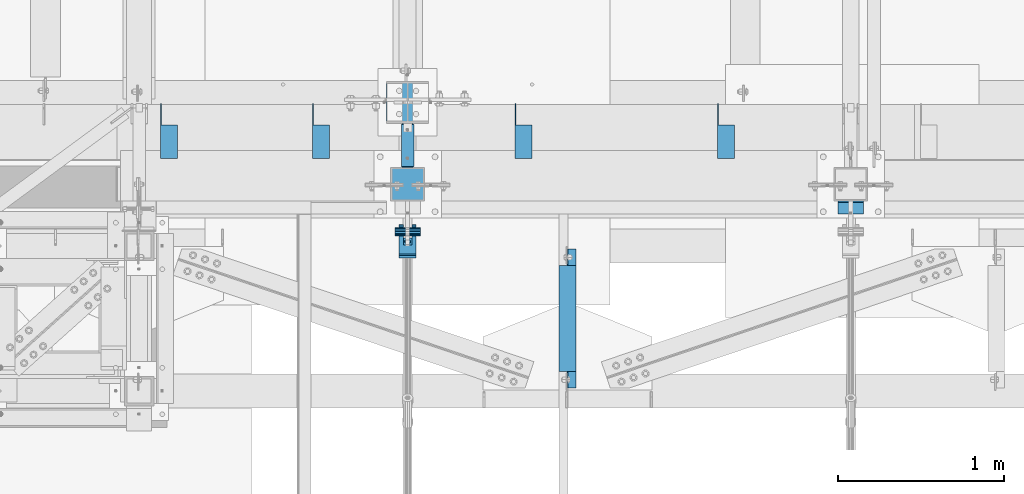
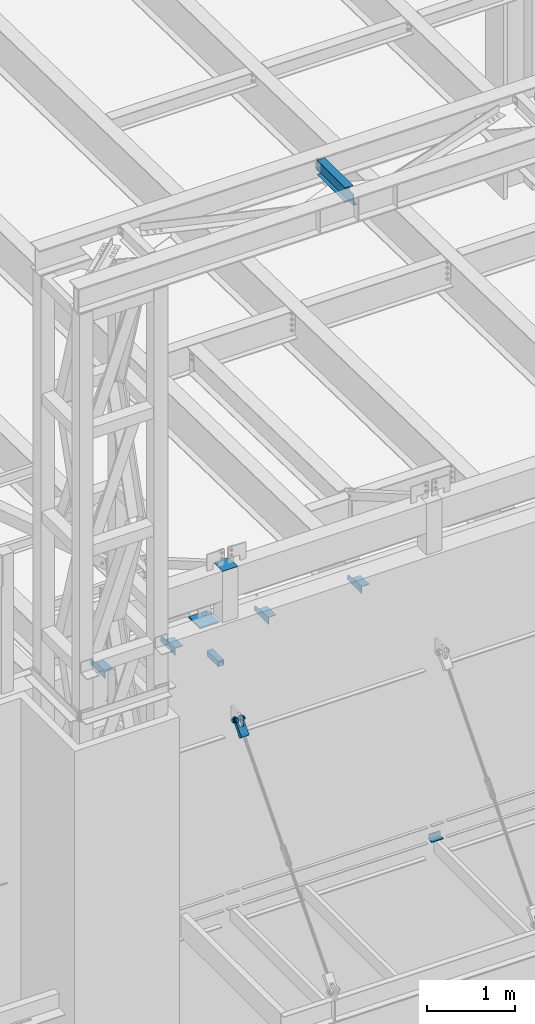
# One storey, part 1202 of 1763: 10 beams, 1 member, 8 elements without a shape of their own.
"""IFC2X3 building model written with IfcOpenShell, lengths in millimetres."""

from ifc_helpers import new_model, si_unit, frame, origin_with_axes, place, context, subcontext, project, spatial, faceted_brep, material, type_object, element, aggregate, save


model = new_model("IFC2X3")

# Units and contexts
model_context = context("Model", 3, precision=1e-05, world=origin_with_axes())
body_context = subcontext(model_context, "Body", "Model", "MODEL_VIEW")
ifc_project = project(units=[si_unit("LENGTHUNIT", "METRE", prefix="MILLI"), si_unit("AREAUNIT", "SQUARE_METRE"), si_unit("VOLUMEUNIT", "CUBIC_METRE"), si_unit("MASSUNIT", "GRAM", prefix="KILO"), si_unit("TIMEUNIT", "SECOND"), si_unit("PLANEANGLEUNIT", "RADIAN"), si_unit("SOLIDANGLEUNIT", "STERADIAN"), si_unit("THERMODYNAMICTEMPERATUREUNIT", "DEGREE_CELSIUS"), si_unit("LUMINOUSINTENSITYUNIT", "LUMEN")], contexts=[model_context])

# Site, building, storey
site_placement = place(None, origin_with_axes())
site = spatial("IfcSite", under=ifc_project, at=site_placement, CompositionType="ELEMENT")
building_placement = place(site_placement, origin_with_axes())
building = spatial("IfcBuilding", under=site, at=building_placement, Name="Undefined", CompositionType="ELEMENT")
storey_placement = place(building_placement, origin_with_axes())
storey = spatial("IfcBuildingStorey", under=building, at=storey_placement, Name="Undefined", CompositionType="ELEMENT", Elevation=0.0)

# Assembly, beams
assembly_1_placement = place(storey_placement, origin_with_axes())
assembly_1 = element("IfcElementAssembly", 1, at=assembly_1_placement, inside=storey, Name="BEAM", AssemblyPlace="NOTDEFINED", PredefinedType="RIGID_FRAME")
ifc_material_1 = material(Name="STEEL/A36")
beam_type_1 = type_object("IfcBeamType", Name="L4X4X1/4", PredefinedType="NOTDEFINED")
beam_1_placement = place(assembly_1_placement, frame((-59677.6055562795, -13723.1435701432, 12153.9), z_axis=(0.0, 0.0, -1.0), x_axis=(0.0, -1.0, 0.0)))
beam_1 = element("IfcBeam", 2, at=beam_1_placement, type_object=beam_type_1, material=ifc_material_1, Name="BRACE", ObjectType="L4X4X1/4", context=body_context, shape_type="Brep", body=[
    faceted_brep([(127.793748474227, 44.4499999999971, -31.7500007627295), (127.793748474227, 50.8000000000029, -31.7500007627295), (127.793748474225, 50.8000000000029, -50.7999999999993), (127.793748474225, -50.8000000000029, -50.7999999999993), (127.793748474225, -50.8000000000029, -44.4500000000007), (127.793748474225, 44.4499999999971, -44.4500000000007), (31.7499999999673, 44.4499999999971, -31.7500001906901), (31.7499999999673, 50.8000000000029, -31.7500007627295), (-1.81898940354586e-10, 44.4500000000371, 50.7999999999374), (-1.96450855582952e-10, 50.8000000000393, 50.7999999999374), (0.0, 50.8000000000029, -1.90690116141923e-07), (0.0, 44.4499999999971, -1.90690116141923e-07), (329.406260681253, 44.4499999999971, 50.7999999999993), (329.406260681253, 50.8000000000029, 50.7999999999993), (329.406260681253, 44.4499999999971, -44.4500000000007), (329.406260681253, -50.8000000000029, -44.4500000000007), (329.406260681253, -50.8000000000029, -50.7999999999993), (329.406260681253, 50.8000000000029, -50.7999999999993)], [[[0, 1, 2, 3, 4, 5]], [[1, 0, 6, 7]], [[8, 9, 10, 11]], [[9, 8, 12, 13]], [[12, 14, 15, 16, 17, 13]], [[15, 14, 5, 4]], [[16, 15, 4, 3]], [[17, 16, 3, 2]], [[9, 13, 17, 2, 1, 7, 10]], [[6, 11, 10, 7]], [[0, 5, 14, 12, 8, 11, 6]]]),
])
beam_2_placement = place(assembly_1_placement, frame((-60896.8055562795, -13723.1435701432, 12153.9), z_axis=(0.0, 0.0, -1.0), x_axis=(0.0, -1.0, 0.0)))
beam_2 = element("IfcBeam", 3, at=beam_2_placement, type_object=beam_type_1, material=ifc_material_1, Name="BRACE", ObjectType="L4X4X1/4", context=body_context, shape_type="Brep", body=[
    faceted_brep([(31.7499999999673, 44.4499999999971, -31.7500001906901), (0.0, 44.4499999999971, -1.90690116141923e-07), (0.0, 50.8000000000029, -1.90690116141923e-07), (31.7499999999673, 50.8000000000029, -31.7500007627295), (-1.96450855582952e-10, 50.8000000000393, 50.7999999999374), (-1.81898940354586e-10, 44.4500000000371, 50.7999999999374), (329.406260681253, 44.4499999999971, 50.7999999999993), (329.406260681253, 50.8000000000029, 50.7999999999993), (329.406260681253, -50.8000000000029, -50.7999999999993), (329.406260681253, -50.8000000000029, -44.4500000000007), (127.793748474225, -50.8000000000029, -44.4500000000007), (127.793748474225, -50.8000000000029, -50.7999999999993), (329.406260681253, 50.8000000000029, -50.7999999999993), (127.793748474225, 50.8000000000029, -50.7999999999993), (329.406260681253, 44.4499999999971, -44.4500000000007), (127.793748474225, 44.4499999999971, -44.4500000000007), (127.793748474227, 44.4499999999971, -31.7500007627295), (127.793748474227, 50.8000000000029, -31.7500007627295)], [[[0, 1, 2, 3]], [[4, 5, 6, 7]], [[8, 9, 10, 11]], [[12, 8, 11, 13]], [[6, 14, 9, 8, 12, 7]], [[9, 14, 15, 10]], [[16, 17, 13, 11, 10, 15]], [[17, 16, 0, 3]], [[4, 7, 12, 13, 17, 3, 2]], [[5, 4, 2, 1]], [[16, 15, 14, 6, 5, 1, 0]]]),
])
aggregate(assembly_1, [beam_1, beam_2])

assembly_2_placement = place(storey_placement, origin_with_axes())
assembly_2 = element("IfcElementAssembly", 4, at=assembly_2_placement, inside=storey, Name="BEAM", AssemblyPlace="NOTDEFINED", PredefinedType="RIGID_FRAME")
beam_3_placement = place(assembly_2_placement, frame((-62116.0055562795, -13723.1435701431, 12153.9), z_axis=(0.0, 0.0, -1.0), x_axis=(0.0, -1.0, 0.0)))
beam_3 = element("IfcBeam", 5, at=beam_3_placement, type_object=beam_type_1, material=ifc_material_1, Name="BRACE", ObjectType="L4X4X1/4", context=body_context, shape_type="Brep", body=[
    faceted_brep([(127.793748474227, 44.4499999999971, -31.7500007627295), (127.793748474227, 50.8000000000029, -31.7500007627295), (127.793748474225, 50.8000000000029, -50.7999999999993), (127.793748474225, -50.8000000000029, -50.7999999999993), (127.793748474225, -50.8000000000029, -44.4500000000007), (127.793748474225, 44.4499999999971, -44.4500000000007), (31.7499999999673, 44.4499999999971, -31.7500001906901), (31.7499999999673, 50.8000000000029, -31.7500007627295), (-1.81898940354586e-10, 44.4500000000371, 50.7999999999374), (-1.96450855582952e-10, 50.8000000000393, 50.7999999999374), (0.0, 50.8000000000029, -1.90690116141923e-07), (0.0, 44.4499999999971, -1.90690116141923e-07), (329.406260681253, 44.4499999999971, 50.7999999999993), (329.406260681253, 50.8000000000029, 50.7999999999993), (329.406260681253, 44.4499999999971, -44.4500000000007), (329.406260681253, -50.8000000000029, -44.4500000000007), (329.406260681253, -50.8000000000029, -50.7999999999993), (329.406260681253, 50.8000000000029, -50.7999999999993)], [[[0, 1, 2, 3, 4, 5]], [[1, 0, 6, 7]], [[8, 9, 10, 11]], [[9, 8, 12, 13]], [[12, 14, 15, 16, 17, 13]], [[15, 14, 5, 4]], [[16, 15, 4, 3]], [[17, 16, 3, 2]], [[9, 13, 17, 2, 1, 7, 10]], [[6, 11, 10, 7]], [[0, 5, 14, 12, 8, 11, 6]]]),
])
beam_4_placement = place(assembly_2_placement, frame((-63030.4055562795, -13723.1435701431, 12153.9), z_axis=(0.0, 0.0, -1.0), x_axis=(0.0, -1.0, 0.0)))
beam_4 = element("IfcBeam", 6, at=beam_4_placement, type_object=beam_type_1, material=ifc_material_1, Name="BRACE", ObjectType="L4X4X1/4", context=body_context, shape_type="Brep", body=[
    faceted_brep([(127.793748474227, 44.4499999999971, -31.7500007627295), (127.793748474227, 50.8000000000029, -31.7500007627295), (127.793748474225, 50.8000000000029, -50.7999999999993), (127.793748474225, -50.8000000000029, -50.7999999999993), (127.793748474225, -50.8000000000029, -44.4500000000007), (127.793748474225, 44.4499999999971, -44.4500000000007), (31.7499999999673, 44.4499999999971, -31.7500001906901), (31.7499999999673, 50.8000000000029, -31.7500007627295), (-1.81898940354586e-10, 44.4500000000371, 50.7999999999374), (-1.96450855582952e-10, 50.8000000000393, 50.7999999999374), (0.0, 50.8000000000029, -1.90690116141923e-07), (0.0, 44.4499999999971, -1.90690116141923e-07), (329.406260681253, 44.4499999999971, 50.7999999999993), (329.406260681253, 50.8000000000029, 50.7999999999993), (329.406260681253, 44.4499999999971, -44.4500000000007), (329.406260681253, -50.8000000000029, -44.4500000000007), (329.406260681253, -50.8000000000029, -50.7999999999993), (329.406260681253, 50.8000000000029, -50.7999999999993)], [[[0, 1, 2, 3, 4, 5]], [[1, 0, 6, 7]], [[8, 9, 10, 11]], [[9, 8, 12, 13]], [[12, 14, 15, 16, 17, 13]], [[15, 14, 5, 4]], [[16, 15, 4, 3]], [[17, 16, 3, 2]], [[9, 13, 17, 2, 1, 7, 10]], [[6, 11, 10, 7]], [[0, 5, 14, 12, 8, 11, 6]]]),
])
aggregate(assembly_2, [beam_3, beam_4])

# Assembly, beam
assembly_3_placement = place(storey_placement, origin_with_axes())
assembly_3 = element("IfcElementAssembly", 7, at=assembly_3_placement, inside=storey, Name="COLUMN", AssemblyPlace="NOTDEFINED", PredefinedType="RIGID_FRAME")
ifc_material_2 = material()
beam_type_2 = type_object("IfcBeamType", Name="HSS3X3X1/4", PredefinedType="NOTDEFINED")
beam_5_placement = place(assembly_3_placement, frame((-61594.4270098568, -14106.5276214906, 11825.2875), z_axis=(0.0, 0.0, 1.0), x_axis=(0.0, 1.0, 0.0)))
beam_5 = element("IfcBeam", 8, at=beam_5_placement, type_object=beam_type_2, material=ifc_material_2, Name="BEAM", ObjectType="HSS3X3X1/4", context=body_context, shape_type="Brep", body=[
    faceted_brep([(263.527621490564, 31.75, 31.75), (263.527621490564, 31.75, -31.75), (257.177621490564, 38.0999999999985, -38.1000000000004), (257.177621490564, 38.0999999999985, 38.1000000000004), (263.527621490564, -31.75, -31.75), (257.177621490564, -38.0999999999985, -38.1000000000004), (263.527621490564, -31.75, 31.75), (257.177621490564, -38.0999999999985, 38.1000000000004), (6.35000000000036, -38.0999999999985, -38.1000000000004), (0.0, -31.75, -31.75), (0.0, 31.75, -31.75), (6.35000000000036, 38.0999999999985, -38.1000000000004), (6.35000000000036, -38.0999999999985, 38.1000000000004), (0.0, -31.75, 31.75), (6.35000000000036, 38.0999999999985, 38.1000000000004), (0.0, 31.75, 31.75)], [[[0, 1, 2, 3]], [[4, 5, 2, 1]], [[6, 7, 5, 4]], [[8, 9, 10, 11]], [[12, 13, 9, 8]], [[14, 15, 13, 12]], [[13, 15, 0, 6]], [[9, 13, 6, 4]], [[10, 9, 4, 1]], [[15, 10, 1, 0]], [[14, 11, 10, 15]], [[11, 14, 3, 2]], [[8, 11, 2, 5]], [[12, 8, 5, 7]], [[14, 12, 7, 3]], [[0, 3, 7, 6]]]),
])

assembly_4_placement = place(storey_placement, origin_with_axes())
assembly_4 = element("IfcElementAssembly", 9, at=assembly_4_placement, inside=storey, Name="BEAM", AssemblyPlace="NOTDEFINED", PredefinedType="RIGID_FRAME")
ifc_material_3 = material(Name="STEEL/A992")
beam_type_3 = type_object("IfcBeamType", Name="W8X10", PredefinedType="NOTDEFINED")
beam_6_placement = place(assembly_4_placement, frame((-60631.3442297049, -15452.7273151462, 18721.3875), z_axis=(0.0, 0.0, 1.0), x_axis=(-6.21520000058808e-05, 0.999999998068564, 0.0)))
beam_6 = element("IfcBeam", 10, at=beam_6_placement, type_object=beam_type_3, material=ifc_material_3, Name="BEAM", ObjectType="W8X10", context=body_context, shape_type="Brep", body=[
    faceted_brep([(119.062681078214, 2.68119467444922, -95.25), (119.062681077521, 2.68146611312113, -100.012500000001), (17.4627485654109, 2.68120642377471, -100.012500000001), (17.4627485487254, 2.68093498508824, -95.25), (119.062558086149, 50.7999999995154, -95.25), (119.062558086149, 50.7999999995154, -100.012500000001), (119.062585395783, -2.38125000033324, 74.3525014877341), (119.062582114406, 2.38124999965657, 74.3525014877341), (118.095852191816, 2.38124999965657, 69.4924219696877), (118.095855473193, -2.38125000033324, 69.4924219696877), (115.342838291333, 2.38124999966385, 65.3722455015341), (115.342841572712, -2.38125000031869, 65.3722455015341), (111.222661823174, 2.38124999968568, 62.6192316010565), (111.222665104551, -2.38125000031141, 62.6192316010565), (106.362582305122, 2.38124999969295, 61.652501678469), (106.362585586499, -2.38125000029686, 61.652501678469), (17.4627301273904, 2.38124999994761, 61.652501678469), (17.4624373812949, -2.3812500000422, 61.652501678469), (17.4624373812949, -2.3812500000422, -95.25), (855.662438966074, -2.38125000246509, -95.25), (855.662438966074, -2.38125000246509, 61.652501678469), (766.762586825173, -2.38125000221044, 61.652501678469), (761.902507307121, -2.38125000219588, 62.6192316010565), (757.78233083896, -2.38125000218133, 65.3722455015341), (755.02931693848, -2.38125000217406, 69.4924219696877), (754.062587015891, -2.38125000216678, 74.3525014877341), (754.062587015991, -2.38125000216678, 95.25), (119.062585395672, -2.38125000033324, 95.25), (17.4594611293232, -50.7999999998938, -95.25), (855.6594627141, -50.8000000023239, -95.25), (17.4594611293232, -50.7999999998938, -100.012500000001), (855.6594627141, -50.8000000023239, -100.012500000001), (754.062536337649, 2.68190379224689, -95.25), (754.062536338066, 2.68163235356769, -100.012500000001), (754.062463102084, 50.7999999976746, -100.012500000001), (754.062463102084, 50.7999999976746, -95.25), (855.662750202562, 2.68205842697353, -95.25), (855.662750185877, 2.68178698828706, -100.012500000001), (855.662731712169, 2.38124999752472, -95.25), (855.662731712169, 2.38124999752472, 61.652501678469), (766.762583543798, 2.38124999777938, 61.652501678469), (761.902504025744, 2.38124999779393, 62.6192316010565), (757.782327557585, 2.38124999780848, 65.3722455015341), (755.029313657102, 2.38124999781576, 69.4924219696877), (754.062583734514, 2.38124999781576, 74.3525014877341), (754.062620376568, -50.8000000020329, 100.012500000001), (754.062620376568, -50.8000000020329, 95.25), (754.062583734623, 2.38124999781576, 95.25), (754.062550374047, 50.7999999976746, 95.25), (754.062550374047, 50.7999999976746, 100.012500000001), (119.062582114304, 2.38124999965657, 95.25), (119.062548753725, 50.7999999995227, 95.25), (119.062548753725, 50.7999999995227, 100.012500000001), (119.062618756248, -50.8000000001921, 100.012500000001), (119.062618756248, -50.8000000001921, 95.25), (17.4627301273904, 2.38124999994761, -95.25)], [[[0, 1, 2, 3]], [[4, 5, 1, 0]], [[6, 7, 8, 9]], [[9, 8, 10, 11]], [[11, 10, 12, 13]], [[13, 12, 14, 15]], [[15, 14, 16, 17]], [[9, 11, 13, 15, 17, 18, 19, 20, 21, 22, 23, 24, 25, 26, 27, 6]], [[18, 28, 29, 19]], [[28, 30, 31, 29]], [[32, 33, 34, 35]], [[36, 37, 33, 32]], [[38, 39, 20, 19, 29, 31, 37, 36]], [[20, 39, 40, 21]], [[21, 40, 41, 22]], [[22, 41, 42, 23]], [[23, 42, 43, 24]], [[24, 43, 44, 25]], [[45, 46, 26, 25, 44, 47, 48, 49]], [[48, 47, 50, 51]], [[49, 48, 51, 52]], [[45, 49, 52, 53]], [[46, 45, 53, 54]], [[26, 46, 54, 27]], [[53, 52, 51, 50, 7, 6, 27, 54]], [[47, 44, 43, 42, 41, 40, 39, 38, 55, 16, 14, 12, 10, 8, 7, 50]], [[30, 28, 18, 17, 16, 55, 3, 2]], [[34, 33, 37, 31, 30, 2, 1, 5]], [[35, 34, 5, 4]], [[55, 38, 36, 32, 35, 4, 0, 3]]]),
])
aggregate(assembly_4, [beam_6])

assembly_5_placement = place(storey_placement, origin_with_axes())
assembly_5 = element("IfcElementAssembly", 11, at=assembly_5_placement, inside=storey, Name="COLUMN", AssemblyPlace="NOTDEFINED", PredefinedType="RIGID_FRAME")
beam_type_4 = type_object("IfcBeamType", Name="L3X3X3/8", PredefinedType="NOTDEFINED")
beam_7_placement = place(assembly_5_placement, frame((-58851.2270154948, -14347.8276478541, 8648.70000000001), z_axis=(0.0, -1.0, 0.0), x_axis=(-1.0, 0.0, 0.0)))
beam_7 = element("IfcBeam", 12, at=beam_7_placement, type_object=beam_type_4, material=ifc_material_1, Name="ANGLE", ObjectType="L3X3X3/8", context=body_context, shape_type="Brep", body=[
    faceted_brep([(0.0, 38.0999999999985, -38.1000000000004), (0.0, 38.0999999999985, 38.1000000000004), (152.400006103515, 38.0999999999985, 38.1000000000058), (152.400006103515, 38.0999999999985, -38.1000000000058), (1.45519152283669e-11, 28.5750000000007, 38.1000000000022), (152.400000000023, 28.5750000000007, 38.0999999999622), (0.0, 28.5750000000007, -28.5750000000007), (152.400000000009, 28.5750000000007, -28.5750000000389), (0.0, -38.1000000000004, -28.5750000000007), (152.400000000009, -38.1000000000004, -28.5750000000389), (0.0, -38.0999999999985, -38.1000000000004), (152.400006103515, -38.0999999999985, -38.1000000000058)], [[[0, 1, 2, 3]], [[1, 4, 5, 2]], [[4, 6, 7, 5]], [[6, 8, 9, 7]], [[8, 10, 11, 9]], [[10, 0, 3, 11]], [[5, 7, 9, 11, 3, 2]], [[10, 8, 6, 4, 1, 0]]]),
])
aggregate(assembly_5, [beam_7])

assembly_6_placement = place(storey_placement, origin_with_axes())
assembly_6 = element("IfcElementAssembly", 13, at=assembly_6_placement, inside=storey, Name="PIN", AssemblyPlace="NOTDEFINED", PredefinedType="RIGID_FRAME")
beam_type_5 = type_object("IfcBeamType", PredefinedType="NOTDEFINED")
beam_8_placement = place(assembly_6_placement, frame((-61670.627008321, -14493.8776228191, 11290.3000019096), z_axis=(0.0, 0.0, 1.0), x_axis=(1.0, 0.0, 0.0)))
beam_8 = element("IfcBeam", 14, at=beam_8_placement, type_object=beam_type_5, material=ifc_material_2, Name="PIN", context=body_context, shape_type="Brep", body=[
    faceted_brep([(0.0, -25.4000000000015, 0.0), (0.0, -23.466540125788, -9.72015918207308), (152.400103102711, -23.466540125788, -9.72015918207308), (152.400103102711, -25.4000000000015, 0.0), (0.0, -17.9605122421381, -17.9605122421385), (152.400103102711, -17.9605122421381, -17.9605122421385), (0.0, -9.72015918207398, -23.4665401257867), (152.400103102711, -9.72015918207398, -23.4665401257867), (0.0, 0.0, -25.4000000000001), (152.400103102711, 0.0, -25.4000000000001), (0.0, 9.72015918207398, -23.4665401257867), (152.400103102711, 9.72015918207398, -23.4665401257867), (0.0, 17.9605122421381, -17.9605122421385), (152.400103102711, 17.9605122421381, -17.9605122421385), (0.0, 23.466540125788, -9.72015918207308), (152.400103102711, 23.466540125788, -9.72015918207308), (0.0, 25.4000000000015, 0.0), (152.400103102711, 25.4000000000015, 0.0), (0.0, 23.466540125788, 9.72015918207308), (152.400103102711, 23.466540125788, 9.72015918207308), (0.0, 17.9605122421381, 17.9605122421385), (152.400103102711, 17.9605122421381, 17.9605122421385), (0.0, 9.72015918207398, 23.4665401257867), (152.400103102711, 9.72015918207398, 23.4665401257867), (0.0, 0.0, 25.4000000000001), (152.400103102711, 0.0, 25.4000000000001), (0.0, -9.72015918207398, 23.4665401257867), (152.400103102711, -9.72015918207398, 23.4665401257867), (0.0, -17.9605122421381, 17.9605122421385), (152.400103102711, -17.9605122421381, 17.9605122421385), (0.0, -23.466540125788, 9.72015918207308), (152.400103102711, -23.466540125788, 9.72015918207308)], [[[0, 1, 2, 3]], [[1, 4, 5, 2]], [[4, 6, 7, 5]], [[6, 8, 9, 7]], [[8, 10, 11, 9]], [[10, 12, 13, 11]], [[12, 14, 15, 13]], [[14, 16, 17, 15]], [[16, 18, 19, 17]], [[18, 20, 21, 19]], [[20, 22, 23, 21]], [[22, 24, 25, 23]], [[24, 26, 27, 25]], [[26, 28, 29, 27]], [[28, 30, 31, 29]], [[30, 0, 3, 31]], [[5, 7, 9, 11, 13, 15, 17, 19, 21, 23, 25, 27, 29, 31, 3, 2]], [[30, 28, 26, 24, 22, 20, 18, 16, 14, 12, 10, 8, 6, 4, 1, 0]]]),
])
aggregate(assembly_6, [beam_8])

# Assembly, member
assembly_7_placement = place(storey_placement, origin_with_axes())
assembly_7 = element("IfcElementAssembly", 15, at=assembly_7_placement, inside=storey, Name="HANGER ROD", AssemblyPlace="NOTDEFINED", PredefinedType="RIGID_FRAME")
member_type = type_object("IfcMemberType", PredefinedType="NOTDEFINED")
member_placement = place(assembly_7_placement, frame((-61594.4270083209, -14464.5701432834, 11323.7196689226), z_axis=(-1.0, 0.0, 0.0), x_axis=(0.0, -0.659331697240892, -0.751852188274693)))
member = element("IfcMember", 16, at=member_placement, type_object=member_type, material=ifc_material_1, context=body_context, shape_type="Brep", body=[
    faceted_brep([(254.000002114522, 9.52500000169675, 16.4977839419953), (134.273330688089, 9.52500000160944, 16.4977839419953), (134.273330688083, 16.4977839436942, 9.52499999989959), (254.000002182145, 16.4977839437852, 9.52499999989959), (134.273330688081, 19.0500000015963, -1.01863406598568e-10), (254.000002023278, 19.0500000016909, -1.01863406598568e-10), (134.273330688083, 16.4977839436942, -9.52500000010332), (254.000001680489, 16.4977839437852, -9.52500000010332), (134.273330688089, 9.52500000160944, -16.497783942199), (254.000001245629, 9.52500000169675, -16.497783942199), (134.273330688098, 1.61890056915581e-09, -19.0500000001048), (254.000000835218, 1.70985003933311e-09, -19.0500000001048), (134.273330688103, -9.52499999837164, -16.497783942199), (254.000000559224, -9.52499999827705, -16.497783942199), (134.273330688109, -16.4977839404564, -9.52500000010332), (254.000000491603, -16.4977839403655, -9.52500000010332), (134.273330688112, -19.0499999983585, -1.01863406598568e-10), (254.000000650468, -19.0499999982676, -1.01863406598568e-10), (134.273330688109, -16.4977839404564, 9.52499999989959), (254.000000993259, -16.4977839403655, 9.52499999989959), (134.273330688103, -9.52499999837164, 16.4977839419953), (254.000001428119, -9.52499999827705, 16.4977839419953), (134.273330688098, 1.61890056915581e-09, 19.049999999901), (254.00000183853, 1.70985003933311e-09, 19.049999999901), (78.4980859522016, 28.5827170717785, -50.8000000000029), (71.5070499125045, 35.2741161661834, -50.8000000000029), (71.5070499125045, 35.2741161661834, -25.3999992370664), (78.4980859522016, 28.5827170717785, -25.3999992370664), (63.2335594920528, 40.2939531168813, -50.8000000000029), (63.2335594920528, 40.2939531168813, -25.3999992370664), (54.0697628847552, 43.4042969063921, -50.8000000000029), (54.0697628847552, 43.4042969063921, -25.3999992370664), (44.4500000032872, 44.4500000000189, -50.8000000000029), (44.4500000032872, 44.4500000003973, -25.3999992370664), (27.4397209215654, 41.0664449477481, -50.8000000000029), (27.4397209215654, 41.0664449477481, -25.3999992370664), (13.0191026972475, 31.4308957019275, -50.8000000000029), (13.0191026972475, 31.4308957019275, -25.3999992370664), (3.38355373177319, 17.0102772902901, -50.8000000000029), (3.38355373177319, 17.0102772902901, -25.3999992370664), (0.0, 0.0, -50.7999992370605), (0.0, 0.0, -25.4000000000001), (3.38355545789955, -17.0102785002382, -50.8000000000029), (3.38355545789955, -17.0102785002382, -25.3999992370664), (13.0191044786457, -31.4308962839314, -50.8000000000029), (13.0191044786457, -31.4308962839314, -25.3999992370664), (27.4397222623497, -41.066445304652, -50.8000000000029), (27.4397222623497, -41.066445304652, -25.3999992370664), (44.4500007625898, -44.4499999999498, -50.8000000000029), (44.4500007625898, -44.4500001906781, -25.3999992370664), (54.0697566383383, -43.3965760809588, -50.8000000000029), (54.0697566383383, -43.3965760809588, -25.3999992370664), (63.2335536920523, -40.2862336066682, -50.8000000000029), (63.2335536920523, -40.2862336066682, -25.3999992370664), (71.507044832973, -35.266397843403, -50.8000000000029), (71.507044832973, -35.266397843403, -25.3999992370664), (78.4980818330437, -28.5749997523744, -50.8000000000029), (78.4980818330437, -28.5749997523744, -25.3999992370664), (71.5070499125045, 35.2741161661834, 50.8000000000029), (78.4980859522016, 28.5827170717785, 50.8000000000029), (78.4980859522016, 28.5827170717785, 25.3999999999942), (71.5070499125045, 35.2741161661834, 25.3999999999942), (63.2335594920528, 40.2939531168813, 50.8000000000029), (63.2335594920528, 40.2939531168813, 25.3999999999942), (54.0697628847552, 43.4042969063921, 50.8000000000029), (54.0697628847552, 43.4042969063921, 25.3999999999942), (44.4500000032872, 44.4500000015396, 50.8000000000029), (44.450000003289, 44.4500000011612, 25.3999999999942), (27.4397209215654, 41.0664449477481, 50.8000000000029), (27.4397209215654, 41.0664449477481, 25.3999999999942), (13.0191026972475, 31.4308957019275, 50.8000000000029), (13.0191026972475, 31.4308957019275, 25.3999999999942), (3.38355373177319, 17.0102772902901, 50.8000000000029), (3.38355373177319, 17.0102772902901, 25.3999999999942), (0.0, 0.0, 50.7999992370605), (0.0, 0.0, 25.4000000000001), (3.38355545789955, -17.0102785002382, 50.8000000000029), (3.38355545789955, -17.0102785002382, 25.3999999999942), (13.0191044786457, -31.4308962839314, 50.8000000000029), (13.0191044786457, -31.4308962839314, 25.3999999999942), (27.4397222623497, -41.066445304652, 50.8000000000029), (27.4397222623497, -41.066445304652, 25.3999999999942), (44.4500007625898, -44.4500007628594, 50.8000000000029), (44.4500007625898, -44.4500005721347, 25.3999999999942), (54.0697566383383, -43.3965760809588, 50.8000000000029), (54.0697566383383, -43.3965760809588, 25.3999999999942), (63.2335536920523, -40.2862336066682, 50.8000000000029), (63.2335536920523, -40.2862336066682, 25.3999999999942), (71.507044832973, -35.266397843403, 50.8000000000029), (71.507044832973, -35.266397843403, 25.3999999999942), (78.4980818330437, -28.5749997523744, 50.8000000000029), (78.4980818330437, -28.5749997523744, 25.3999999999942), (215.900005804647, -28.5749978020685, -50.8000000000029), (215.900005804647, -28.5749978020685, 50.8000000000029), (134.273330688118, -28.574998960692, 25.3999999999942), (134.273330688118, -28.574998960692, -25.3999992370664), (215.899998542161, -41.274998426099, -50.8000000000029), (215.899998542161, -41.274998426099, 50.8000000000029), (254.000000615249, -28.5749978178974, 50.8000000000029), (253.999999999285, -28.5749978178974, -50.8000000000029), (253.999999999241, 28.5826899486601, -50.8000000000029), (254.000004734274, 28.5826899486601, 50.8000000000029), (215.900009923701, 28.5826954010772, 50.8000000000029), (215.900004483963, 41.2826960251004, 50.8000000000029), (65.3837779449618, -23.8713099949055, 50.8000000000029), (54.6551341370573, -30.0652247148719, 50.8000000000029), (42.3728511665136, -31.6819815137387, 50.8000000000029), (30.4067952764267, -28.4754438248128, 50.8000000000029), (20.5786900034959, -20.9337779439011, 50.8000000000029), (14.3847752835277, -10.2051341359947, 50.8000000000029), (12.7680184846608, 2.07714883454901, 50.8000000000029), (15.9745561735849, 14.0432047246359, 50.8000000000029), (23.5162220544985, 23.8713099975648, 50.8000000000029), (34.2448658624066, 30.0652247175349, 50.8000000000029), (46.5271488329486, 31.6819815164017, 50.8000000000029), (58.4932047230354, 28.4754438274795, 50.8000000000029), (68.3213099959662, 20.9337779465641, 50.8000000000029), (74.5152247159344, 10.2051341386577, 50.8000000000029), (76.1319815147995, -2.07714883188601, 50.8000000000029), (72.9254438258772, -14.0432047219729, 50.8000000000029), (65.3837779449618, -23.8713099949055, 25.3999999999942), (54.6551341370573, -30.0652247148719, 25.3999999999942), (42.3728511665136, -31.6819815137387, 25.3999999999942), (30.4067952764267, -28.4754438248128, 25.3999999999942), (20.5786900034959, -20.9337779439011, 25.3999999999942), (14.3847752835277, -10.2051341359947, 25.3999999999942), (12.7680184846608, 2.07714883454901, 25.3999999999942), (15.9745561735849, 14.0432047246359, 25.3999999999942), (23.5162220544985, 23.8713099975648, 25.3999999999942), (34.2448658624066, 30.0652247175349, 25.3999999999942), (46.5271488329486, 31.6819815164017, 25.3999999999942), (58.4932047230354, 28.4754438274795, 25.3999999999942), (68.3213099959662, 20.9337779465641, 25.3999999999942), (74.5152247159344, 10.2051341386577, 25.3999999999942), (76.1319815147995, -2.07714883188601, 25.3999999999942), (72.9254438258772, -14.0432047219729, 25.3999999999942), (134.273330688074, 28.5827082750402, 25.3999999999942), (215.900009923701, 28.5826954010772, -50.8000000000029), (134.273330688074, 28.5827082750402, -25.3999992370664), (215.900004483963, 41.2826960251004, -50.8000000000029), (68.3213099959662, 20.9337779465641, -50.8000000000029), (58.4932047230354, 28.4754438274795, -50.8000000000029), (46.5271488329486, 31.6819815164017, -50.8000000000029), (34.2448658624066, 30.0652247175349, -50.8000000000029), (23.5162220544985, 23.8713099975648, -50.8000000000029), (15.9745561735849, 14.0432047246359, -50.8000000000029), (12.7680184846608, 2.07714883454901, -50.8000000000029), (14.3847752835277, -10.2051341359947, -50.8000000000029), (20.5786900034959, -20.9337779439011, -50.8000000000029), (30.4067952764267, -28.4754438248128, -50.8000000000029), (42.3728511665136, -31.6819815137387, -50.8000000000029), (54.6551341370573, -30.0652247148719, -50.8000000000029), (65.3837779449618, -23.8713099949055, -50.8000000000029), (72.9254438258772, -14.0432047219729, -50.8000000000029), (76.1319815147995, -2.07714883188601, -50.8000000000029), (74.5152247159344, 10.2051341386577, -50.8000000000029), (68.3213099959662, 20.9337779465641, -25.3999992370664), (58.4932047230354, 28.4754438274795, -25.3999992370664), (46.5271488329486, 31.6819815164017, -25.3999992370664), (34.2448658624066, 30.0652247175349, -25.3999992370664), (23.5162220544985, 23.8713099975648, -25.3999992370664), (15.9745561735849, 14.0432047246359, -25.3999992370664), (12.7680184846608, 2.07714883454901, -25.3999992370664), (14.3847752835277, -10.2051341359947, -25.3999992370664), (20.5786900034959, -20.9337779439011, -25.3999992370664), (30.4067952764267, -28.4754438248128, -25.3999992370664), (42.3728511665136, -31.6819815137387, -25.3999992370664), (54.6551341370573, -30.0652247148719, -25.3999992370664), (65.3837779449618, -23.8713099949055, -25.3999992370664), (72.9254438258772, -14.0432047219729, -25.3999992370664), (76.1319815147995, -2.07714883188601, -25.3999992370664), (74.5152247159344, 10.2051341386577, -25.3999992370664)], [[[0, 1, 2, 3]], [[3, 2, 4, 5]], [[5, 4, 6, 7]], [[7, 6, 8, 9]], [[9, 8, 10, 11]], [[11, 10, 12, 13]], [[13, 12, 14, 15]], [[15, 14, 16, 17]], [[17, 16, 18, 19]], [[19, 18, 20, 21]], [[21, 20, 22, 23]], [[23, 22, 1, 0]], [[24, 25, 26, 27]], [[25, 28, 29, 26]], [[28, 30, 31, 29]], [[30, 32, 33, 31]], [[32, 34, 35, 33]], [[34, 36, 37, 35]], [[36, 38, 39, 37]], [[38, 40, 41, 39]], [[40, 42, 43, 41]], [[42, 44, 45, 43]], [[44, 46, 47, 45]], [[46, 48, 49, 47]], [[48, 50, 51, 49]], [[50, 52, 53, 51]], [[52, 54, 55, 53]], [[54, 56, 57, 55]], [[58, 59, 60, 61]], [[62, 58, 61, 63]], [[64, 62, 63, 65]], [[66, 64, 65, 67]], [[68, 66, 67, 69]], [[70, 68, 69, 71]], [[72, 70, 71, 73]], [[74, 72, 73, 75]], [[76, 74, 75, 77]], [[78, 76, 77, 79]], [[80, 78, 79, 81]], [[82, 80, 81, 83]], [[84, 82, 83, 85]], [[86, 84, 85, 87]], [[88, 86, 87, 89]], [[90, 88, 89, 91]], [[57, 56, 92, 93, 90, 91, 94, 95]], [[93, 92, 96, 97]], [[98, 97, 96, 99]], [[98, 99, 100, 101], [3, 5, 7, 9, 11, 13, 15, 17, 19, 21, 23, 0]], [[102, 59, 58, 62, 64, 66, 68, 70, 72, 74, 76, 78, 80, 82, 84, 86, 88, 90, 93, 97, 98, 101, 103], [104, 105, 106, 107, 108, 109, 110, 111, 112, 113, 114, 115, 116, 117, 118, 119]], [[105, 104, 120, 121]], [[106, 105, 121, 122]], [[107, 106, 122, 123]], [[108, 107, 123, 124]], [[109, 108, 124, 125]], [[110, 109, 125, 126]], [[111, 110, 126, 127]], [[112, 111, 127, 128]], [[113, 112, 128, 129]], [[114, 113, 129, 130]], [[115, 114, 130, 131]], [[116, 115, 131, 132]], [[117, 116, 132, 133]], [[118, 117, 133, 134]], [[119, 118, 134, 135]], [[104, 119, 135, 120]], [[91, 89, 87, 85, 83, 81, 79, 77, 75, 73, 71, 69, 67, 65, 63, 61, 60, 136, 94], [134, 133, 132, 131, 130, 129, 128, 127, 126, 125, 124, 123, 122, 121, 120, 135]], [[59, 102, 137, 24, 27, 138, 136, 60]], [[103, 139, 137, 102]], [[101, 100, 139, 103]], [[99, 96, 92, 56, 54, 52, 50, 48, 46, 44, 42, 40, 38, 36, 34, 32, 30, 28, 25, 24, 137, 139, 100], [140, 141, 142, 143, 144, 145, 146, 147, 148, 149, 150, 151, 152, 153, 154, 155]], [[141, 140, 156, 157]], [[142, 141, 157, 158]], [[143, 142, 158, 159]], [[144, 143, 159, 160]], [[145, 144, 160, 161]], [[146, 145, 161, 162]], [[147, 146, 162, 163]], [[148, 147, 163, 164]], [[149, 148, 164, 165]], [[150, 149, 165, 166]], [[151, 150, 166, 167]], [[152, 151, 167, 168]], [[153, 152, 168, 169]], [[154, 153, 169, 170]], [[155, 154, 170, 171]], [[140, 155, 171, 156]], [[95, 138, 27, 26, 29, 31, 33, 35, 37, 39, 41, 43, 45, 47, 49, 51, 53, 55, 57], [170, 169, 168, 167, 166, 165, 164, 163, 162, 161, 160, 159, 158, 157, 156, 171]], [[94, 136, 138, 95], [18, 16, 14, 12, 10, 8, 6, 4, 2, 1, 22, 20]]]),
])
aggregate(assembly_7, [member])

# Beam
beam_type_6 = type_object("IfcBeamType", PredefinedType="NOTDEFINED")
beam_9_placement = place(assembly_3_placement, frame((-61594.4270098568, -14309.7276214906, 13255.6471257957), z_axis=(1.0, 0.0, 0.0), x_axis=(0.0, 1.0, 0.0)))
beam_9 = element("IfcBeam", 17, at=beam_9_placement, type_object=beam_type_6, material=ifc_material_1, Name="PLATE", context=body_context, shape_type="Brep", body=[
    faceted_brep([(0.0, 3.1749999995518, -101.600000000005), (0.0, 3.17499999999927, 101.599998474121), (203.200000000001, 3.17500000054133, 101.600000000011), (203.200000000001, 3.1749999995518, -101.600000000005), (0.0, -3.17499999999927, 101.599998474121), (203.200000000001, -3.17499999950815, 101.600000000005), (0.0, -3.17500000051223, -101.600000000012), (203.200000000001, -3.17500000051223, -101.600000000012)], [[[0, 1, 2, 3]], [[1, 4, 5, 2]], [[4, 6, 7, 5]], [[6, 0, 3, 7]], [[5, 7, 3, 2]], [[6, 4, 1, 0]]]),
])

aggregate(assembly_3, [beam_5, beam_9])

# Assembly, beam
assembly_8_placement = place(storey_placement, origin_with_axes())
assembly_8 = element("IfcElementAssembly", 18, at=assembly_8_placement, inside=storey, Name="COLUMN", AssemblyPlace="NOTDEFINED", PredefinedType="RIGID_FRAME")
ifc_material_4 = material(Name="STEEL/A572-50")
beam_type_7 = type_object("IfcBeamType", PredefinedType="NOTDEFINED")
beam_10_placement = place(assembly_8_placement, frame((-61594.4372736983, -13843.0, 12195.175), z_axis=(1.0, 0.0, 0.0), x_axis=(0.0, 1.0, 0.0)))
beam_10 = element("IfcBeam", 19, at=beam_10_placement, type_object=beam_type_7, material=ifc_material_4, Name="PLATE", context=body_context, shape_type="Brep", body=[
    faceted_brep([(0.0, 9.52499999999964, -127.0), (0.0, 9.52499999999964, 127.0), (254.0, 9.52499999999964, 127.0), (254.0, 9.52499999999964, -127.0), (0.0, -9.52499999999964, 127.0), (254.0, -9.52499999999964, 127.0), (0.0, -9.52499999999964, -127.0), (254.0, -9.52499999999964, -127.0)], [[[0, 1, 2, 3]], [[1, 4, 5, 2]], [[4, 6, 7, 5]], [[6, 0, 3, 7]], [[5, 7, 3, 2]], [[6, 4, 1, 0]]]),
])
aggregate(assembly_8, [beam_10])

save(model, "model.ifc")
